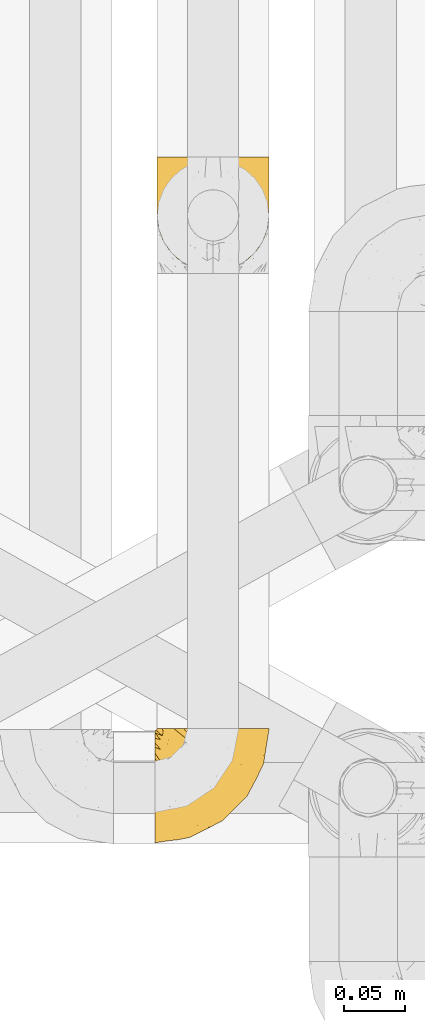
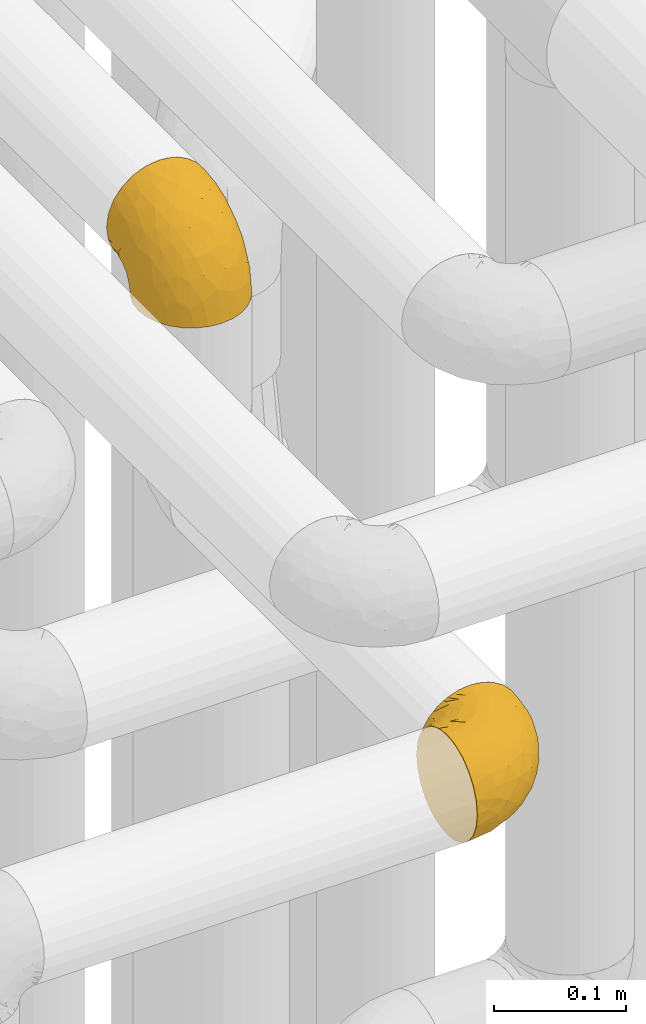
# One storey, part 149 of 827: 2 coverings.
"""IFC2X3 building model written with IfcOpenShell, lengths in millimetres."""

from ifc_helpers import new_model, entity, si_unit, converted_unit, derived_unit, direction, frame, origin, place, context, subcontext, project, spatial, faceted_brep, element, save


model = new_model("IFC2X3")

# Units and contexts
model_context = context("Model", 3, precision=0.01, world=origin(), true_north=direction((6.12303176911189e-17, 1.0)))
body_context = subcontext(model_context, "Body", "Model", "MODEL_VIEW")
ifc_project = project(units=[si_unit("LENGTHUNIT", "METRE", prefix="MILLI"), si_unit("AREAUNIT", "SQUARE_METRE"), si_unit("VOLUMEUNIT", "CUBIC_METRE"), converted_unit("PLANEANGLEUNIT", "DEGREE", entity("IfcRatioMeasure", 0.0174532925199433), si_unit("PLANEANGLEUNIT", "RADIAN"), dimensions=[0, 0, 0, 0, 0, 0, 0]), si_unit("MASSUNIT", "GRAM", prefix="KILO"), derived_unit("MASSDENSITYUNIT", [(si_unit("MASSUNIT", "GRAM", prefix="KILO"), 1), (si_unit("LENGTHUNIT", "METRE"), -3)]), derived_unit("MOMENTOFINERTIAUNIT", [(si_unit("LENGTHUNIT", "METRE"), 4)]), si_unit("TIMEUNIT", "SECOND"), si_unit("FREQUENCYUNIT", "HERTZ"), si_unit("THERMODYNAMICTEMPERATUREUNIT", "DEGREE_CELSIUS"), derived_unit("THERMALTRANSMITTANCEUNIT", [(si_unit("MASSUNIT", "GRAM", prefix="KILO"), 1), (si_unit("THERMODYNAMICTEMPERATUREUNIT", "KELVIN"), -1), (si_unit("TIMEUNIT", "SECOND"), -3)]), derived_unit("VOLUMETRICFLOWRATEUNIT", [(si_unit("LENGTHUNIT", "METRE"), 3), (si_unit("TIMEUNIT", "SECOND"), -1)]), derived_unit("MASSFLOWRATEUNIT", [(si_unit("MASSUNIT", "GRAM", prefix="KILO"), 1), (si_unit("TIMEUNIT", "SECOND"), -1)]), derived_unit("ROTATIONALFREQUENCYUNIT", [(si_unit("TIMEUNIT", "SECOND"), -1)]), si_unit("ELECTRICCURRENTUNIT", "AMPERE"), si_unit("ELECTRICVOLTAGEUNIT", "VOLT"), si_unit("POWERUNIT", "WATT"), si_unit("FORCEUNIT", "NEWTON", prefix="KILO"), si_unit("ILLUMINANCEUNIT", "LUX"), si_unit("LUMINOUSFLUXUNIT", "LUMEN"), si_unit("LUMINOUSINTENSITYUNIT", "CANDELA"), derived_unit("USERDEFINED", [(si_unit("MASSUNIT", "GRAM", prefix="KILO"), -1), (si_unit("LENGTHUNIT", "METRE"), -2), (si_unit("TIMEUNIT", "SECOND"), 3), (si_unit("LUMINOUSFLUXUNIT", "LUMEN"), 1)]), derived_unit("LINEARVELOCITYUNIT", [(si_unit("LENGTHUNIT", "METRE"), 1), (si_unit("TIMEUNIT", "SECOND"), -1)]), si_unit("PRESSUREUNIT", "PASCAL"), derived_unit("USERDEFINED", [(si_unit("LENGTHUNIT", "METRE"), -2), (si_unit("MASSUNIT", "GRAM", prefix="KILO"), 1), (si_unit("TIMEUNIT", "SECOND"), -2)]), derived_unit("LINEARFORCEUNIT", [(si_unit("MASSUNIT", "GRAM", prefix="KILO"), 1), (si_unit("LENGTHUNIT", "METRE"), 1), (si_unit("TIMEUNIT", "SECOND"), -2), (si_unit("LENGTHUNIT", "METRE"), -1)]), derived_unit("PLANARFORCEUNIT", [(si_unit("MASSUNIT", "GRAM", prefix="KILO"), 1), (si_unit("LENGTHUNIT", "METRE"), 1), (si_unit("TIMEUNIT", "SECOND"), -2), (si_unit("LENGTHUNIT", "METRE"), -2)])], contexts=[model_context])

# Site, building, storey
site_placement = place(None, origin())
site = spatial("IfcSite", under=ifc_project, at=site_placement, CompositionType="ELEMENT")
building_placement = place(site_placement, origin())
building = spatial("IfcBuilding", under=site, at=building_placement, CompositionType="ELEMENT")
storey_placement = place(building_placement, frame((0.0, 0.0, 28200.0)))
storey = spatial("IfcBuildingStorey", under=building, at=storey_placement, Name="08", CompositionType="ELEMENT", Elevation=28200.0)

# Coverings
covering_1_placement = place(storey_placement, frame((35552.3, 10780.58, 3350.4)))
element("IfcCovering", 1, at=covering_1_placement, inside=storey, Name=":ADSK_", ObjectType=":ADSK_", PredefinedType="INSULATION", context=body_context, shape_type="Brep", body=[
    faceted_brep([(83.91, 18.98, 1.6), (76.59, 11.67, 1.6), (67.83, 6.17, 1.6), (58.07, 2.75, 1.6), (47.8, 1.6, 1.6), (37.51, 2.75, 1.6), (27.74, 6.17, 1.6), (18.98, 11.68, 1.6), (11.67, 19.0, 1.6), (6.17, 27.76, 1.6), (2.75, 37.52, 1.6), (1.6, 47.8, 1.6), (2.06, 51.94, 1.6), (2.41, 55.01, 1.6), (2.75, 58.08, 1.6), (4.46, 62.96, 1.6), (6.17, 67.85, 1.6), (8.93, 72.23, 1.6), (11.68, 76.61, 1.6), (15.34, 80.26, 1.6), (19.0, 83.92, 1.6), (27.76, 89.42, 1.6), (32.64, 91.13, 1.6), (37.52, 92.84, 1.6), (47.8, 94.0, 1.6), (58.08, 92.84, 1.6), (62.96, 91.13, 1.6), (67.85, 89.42, 1.6), (76.61, 83.91, 1.6), (80.26, 80.25, 1.6), (83.92, 76.59, 1.6), (86.67, 72.21, 1.6), (89.42, 67.83, 1.6), (91.13, 62.95, 1.6), (92.84, 58.07, 1.6), (93.18, 55.0, 1.6), (93.53, 51.94, 1.6), (94.0, 47.8, 1.6), (92.84, 37.51, 1.6), (89.42, 27.74, 1.6), (47.8, 95.8, 3.4), (35.84, 95.8, 4.97), (24.7, 95.8, 9.58), (19.91, 95.8, 13.26), (15.13, 95.8, 16.93), (11.46, 95.8, 21.71), (7.78, 95.8, 26.5), (5.48, 95.8, 32.07), (3.17, 95.8, 37.64), (2.69, 95.8, 41.25), (2.42, 95.8, 43.34), (2.14, 95.8, 45.42), (1.6, 95.8, 49.6), (3.17, 95.8, 61.55), (7.78, 95.8, 72.7), (15.13, 95.8, 82.26), (24.7, 95.8, 89.61), (35.84, 95.8, 94.22), (47.8, 95.8, 95.8), (59.75, 95.8, 94.22), (70.9, 95.8, 89.61), (80.46, 95.8, 82.26), (87.81, 95.8, 72.7), (92.42, 95.8, 61.55), (94.0, 95.8, 49.6), (93.45, 95.8, 45.42), (92.9, 95.8, 41.25), (92.42, 95.8, 37.64), (90.11, 95.8, 32.07), (87.81, 95.8, 26.5), (84.13, 95.8, 21.71), (80.46, 95.8, 16.93), (75.68, 95.8, 13.26), (70.9, 95.8, 9.58), (59.75, 95.8, 4.97), (71.98, 60.58, 81.55), (63.6, 74.11, 90.4), (59.72, 51.59, 83.0), (47.8, 66.69, 91.18), (55.16, 76.19, 93.13), (47.8, 84.43, 94.0), (63.76, 31.2, 66.19), (72.22, 42.88, 70.92), (74.18, 79.41, 85.95), (92.52, 60.7, 49.74), (94.0, 61.85, 35.54), (94.0, 65.75, 38.14), (94.0, 69.64, 40.74), (94.0, 73.53, 43.34), (94.0, 77.43, 45.94), (82.14, 74.59, 77.59), (80.34, 54.72, 71.17), (87.52, 64.18, 65.81), (79.59, 37.94, 59.03), (78.25, 25.89, 45.85), (85.01, 34.73, 45.79), (90.25, 42.89, 41.42), (93.2, 49.83, 34.51), (87.23, 48.58, 56.04), (85.55, 22.41, 15.15), (93.0, 78.69, 56.51), (89.31, 81.64, 68.39), (61.31, 6.22, 23.33), (56.86, 12.11, 42.86), (68.34, 14.81, 39.42), (65.71, 21.61, 53.58), (56.99, 22.41, 59.17), (72.15, 30.12, 59.06), (70.34, 10.01, 22.63), (78.36, 15.36, 20.55), (47.8, 3.39, 12.96), (47.8, 19.59, 56.96), (47.8, 30.01, 67.38), (93.06, 41.19, 18.72), (94.0, 48.54, 5.33), (94.0, 49.28, 9.07), (94.0, 49.82, 11.79), (94.0, 50.37, 14.51), (94.0, 50.91, 17.24), (94.0, 51.45, 19.96), (89.88, 31.61, 21.03), (94.0, 80.15, 46.48), (94.0, 82.88, 47.03), (94.0, 85.6, 47.57), (94.0, 88.32, 48.11), (94.0, 90.19, 48.48), (94.0, 92.06, 48.85), (47.8, 6.21, 30.7), (94.0, 54.05, 23.86), (94.0, 56.65, 27.75), (94.0, 59.25, 31.64), (83.7, 24.66, 31.26), (47.8, 40.43, 77.8), (55.9, 35.17, 72.75), (47.8, 12.9, 43.83), (47.8, 53.56, 84.49), (81.75, 85.34, 14.58), (86.43, 78.44, 16.17), (79.8, 84.37, 10.82), (69.84, 89.05, 4.64), (79.5, 82.76, 7.71), (88.08, 86.31, 25.13), (91.6, 83.73, 32.66), (92.93, 77.31, 34.94), (92.43, 87.78, 36.76), (93.24, 87.91, 40.48), (93.36, 81.29, 39.25), (57.25, 93.97, 3.69), (89.41, 70.76, 13.99), (92.89, 63.67, 21.85), (92.66, 62.62, 17.93), (79.58, 90.64, 15.11), (86.51, 84.08, 21.14), (86.29, 76.28, 12.7), (83.91, 77.45, 7.21), (90.94, 88.72, 32.27), (91.94, 71.28, 25.68), (91.98, 68.09, 22.18), (82.79, 91.07, 18.79), (93.16, 57.47, 10.12), (88.76, 70.34, 9.47), (73.94, 91.35, 10.45), (91.89, 62.99, 11.29), (47.8, 94.52, 2.87), (92.22, 76.47, 31.16), (88.56, 69.96, 6.31), (87.72, 89.86, 25.62), (88.33, 78.94, 21.18), (92.18, 73.51, 28.81), (71.78, 89.62, 7.45), (9.09, 84.09, 21.14), (7.51, 86.3, 25.13), (12.8, 91.06, 18.79), (1.6, 88.32, 48.11), (1.6, 92.06, 48.85), (1.6, 82.88, 47.03), (1.6, 85.6, 47.57), (38.35, 93.97, 3.69), (23.84, 89.63, 7.44), (1.6, 50.37, 14.51), (1.6, 49.82, 11.79), (1.6, 48.54, 5.33), (1.6, 49.28, 9.07), (16.1, 82.77, 7.71), (6.84, 70.36, 9.47), (2.66, 77.31, 34.94), (3.37, 76.47, 31.16), (1.6, 69.64, 40.74), (1.6, 65.75, 38.14), (3.16, 87.78, 36.76), (2.35, 87.91, 40.48), (25.77, 89.06, 4.63), (16.02, 90.65, 15.11), (13.85, 85.35, 14.58), (1.6, 73.53, 43.34), (1.6, 77.43, 45.94), (2.23, 81.29, 39.25), (11.69, 77.46, 7.21), (9.31, 76.29, 12.69), (2.43, 57.47, 10.14), (2.71, 63.71, 21.81), (3.61, 68.11, 22.19), (6.18, 70.77, 14.0), (3.66, 71.31, 25.69), (9.17, 78.46, 16.17), (6.77, 69.52, 6.66), (2.93, 62.64, 17.92), (21.66, 91.35, 10.45), (1.6, 59.25, 31.64), (16.09, 84.6, 10.64), (3.7, 62.98, 11.31), (1.6, 51.45, 19.96), (1.6, 54.05, 23.86), (1.6, 56.65, 27.75), (3.99, 83.73, 32.66), (1.6, 80.15, 46.48), (4.65, 88.72, 32.27), (1.6, 61.85, 35.54), (3.43, 73.56, 28.77), (7.27, 78.96, 21.17), (9.46, 91.36, 23.36), (1.6, 50.91, 17.24), (2.4, 62.87, 47.58), (40.43, 76.19, 93.13), (13.57, 73.57, 77.44), (11.3, 56.07, 66.78), (18.65, 49.77, 71.68), (27.26, 44.73, 74.96), (23.61, 60.58, 81.55), (3.07, 47.64, 36.7), (2.69, 78.32, 56.9), (35.87, 51.59, 83.0), (31.99, 74.11, 90.4), (6.71, 76.04, 67.83), (21.41, 79.41, 85.95), (27.24, 14.82, 39.41), (34.26, 6.22, 23.33), (38.73, 12.12, 42.87), (26.97, 23.51, 53.92), (31.83, 31.2, 66.19), (23.4, 34.96, 64.12), (6.91, 33.86, 33.13), (3.4, 38.94, 23.1), (5.84, 30.23, 16.98), (35.73, 20.67, 55.72), (39.69, 35.17, 72.75), (17.6, 15.85, 23.77), (10.38, 22.59, 18.41), (20.6, 21.56, 43.7), (5.36, 55.94, 54.53), (24.84, 9.19, 17.73), (13.87, 25.79, 38.98), (9.06, 41.16, 50.28), (15.99, 37.95, 59.02)], [[[0, 1, 2, 3, 4, 5, 6, 7, 8, 9, 10, 11, 12, 13, 14, 15, 16, 17, 18, 19, 20, 21, 22, 23, 24, 25, 26, 27, 28, 29, 30, 31, 32, 33, 34, 35, 36, 37, 38, 39]], [[40, 41, 42, 43, 44, 45, 46, 47, 48, 49, 50, 51, 52, 53, 54, 55, 56, 57, 58, 59, 60, 61, 62, 63, 64, 65, 66, 67, 68, 69, 70, 71, 72, 73, 74]], [[75, 76, 77]], [[78, 79, 80]], [[77, 81, 82]], [[76, 75, 83]], [[84, 85, 86, 87, 88, 89]], [[90, 91, 92]], [[76, 60, 59]], [[93, 94, 95]], [[90, 62, 61]], [[83, 61, 60]], [[96, 97, 84]], [[98, 93, 95]], [[0, 39, 99]], [[100, 84, 89]], [[62, 101, 63]], [[2, 102, 3]], [[92, 84, 100]], [[103, 102, 104]], [[103, 105, 106]], [[93, 107, 94]], [[1, 108, 2]], [[92, 101, 90]], [[108, 1, 109]], [[102, 110, 3]], [[93, 82, 107]], [[102, 108, 104]], [[111, 106, 112]], [[109, 0, 99]], [[113, 37, 114, 115, 116, 117, 118, 119]], [[120, 38, 113]], [[100, 89, 121, 122, 123, 124, 125, 126, 64]], [[127, 102, 103]], [[97, 119, 128, 129, 130, 85]], [[99, 120, 131]], [[132, 133, 77]], [[59, 80, 79]], [[1, 0, 109]], [[98, 84, 92]], [[94, 109, 131]], [[120, 39, 38]], [[93, 91, 82]], [[104, 94, 105]], [[97, 113, 119]], [[95, 120, 96]], [[83, 90, 61]], [[91, 93, 98]], [[64, 63, 100]], [[100, 63, 101]], [[77, 76, 79]], [[133, 106, 81]], [[84, 97, 85]], [[113, 96, 120]], [[113, 97, 96]], [[37, 113, 38]], [[110, 102, 127]], [[110, 4, 3]], [[103, 111, 134, 127]], [[90, 75, 91]], [[82, 81, 107]], [[91, 75, 82]], [[77, 82, 75]], [[76, 83, 60]], [[90, 83, 75]], [[105, 107, 81]], [[94, 131, 95]], [[105, 94, 107]], [[109, 94, 104]], [[120, 95, 131]], [[98, 95, 96]], [[84, 98, 96]], [[98, 92, 91]], [[106, 105, 81]], [[103, 104, 105]], [[112, 106, 133]], [[103, 106, 111]], [[112, 133, 132]], [[81, 77, 133]], [[77, 78, 135, 132]], [[120, 99, 39]], [[109, 99, 131]], [[59, 58, 80]], [[59, 79, 76]], [[90, 101, 62]], [[100, 101, 92]], [[2, 108, 102]], [[109, 104, 108]], [[78, 77, 79]], [[136, 137, 138]], [[27, 139, 140]], [[141, 142, 143]], [[144, 145, 121]], [[146, 89, 88]], [[147, 139, 25]], [[148, 149, 150]], [[136, 151, 152]], [[147, 40, 74]], [[24, 147, 25]], [[140, 153, 154]], [[33, 116, 34]], [[73, 72, 151]], [[114, 37, 36, 35, 34, 116, 115]], [[146, 155, 144]], [[156, 85, 130]], [[157, 149, 148]], [[151, 158, 152]], [[117, 33, 159]], [[29, 154, 160]], [[161, 74, 73]], [[162, 128, 119]], [[66, 65, 64, 126, 125, 124, 123, 122, 67]], [[163, 147, 24]], [[27, 140, 28]], [[149, 129, 150]], [[139, 27, 26, 25]], [[68, 144, 69]], [[129, 128, 150]], [[164, 87, 86]], [[130, 129, 149]], [[122, 145, 67]], [[154, 153, 148]], [[162, 119, 159]], [[165, 30, 160]], [[150, 160, 148]], [[128, 162, 150]], [[30, 165, 31]], [[145, 144, 68]], [[89, 146, 144]], [[87, 164, 143]], [[166, 155, 142]], [[88, 87, 143]], [[162, 160, 150]], [[160, 30, 29]], [[154, 29, 28]], [[140, 154, 28]], [[160, 154, 148]], [[140, 137, 153]], [[157, 148, 153]], [[156, 130, 157]], [[153, 137, 157]], [[157, 137, 156]], [[167, 137, 136]], [[168, 85, 156]], [[152, 168, 167]], [[167, 168, 156]], [[164, 152, 141]], [[71, 158, 72]], [[152, 167, 136]], [[88, 142, 146]], [[144, 155, 69]], [[146, 142, 155]], [[70, 166, 71]], [[142, 141, 166]], [[70, 69, 155]], [[141, 158, 71]], [[161, 73, 151]], [[138, 137, 140]], [[161, 136, 169]], [[136, 161, 151]], [[74, 161, 169]], [[152, 158, 141]], [[151, 72, 158]], [[168, 152, 164]], [[137, 167, 156]], [[164, 86, 168]], [[85, 168, 86]], [[116, 33, 117]], [[130, 149, 157]], [[67, 145, 68]], [[121, 89, 144]], [[145, 122, 121]], [[40, 147, 163]], [[169, 147, 74]], [[159, 33, 32]], [[162, 159, 32]], [[159, 119, 118, 117]], [[139, 147, 169]], [[139, 169, 138]], [[162, 32, 31]], [[141, 143, 164]], [[88, 143, 142]], [[71, 166, 141]], [[155, 166, 70]], [[139, 138, 140]], [[169, 136, 138]], [[160, 162, 165]], [[162, 31, 165]], [[170, 171, 172]], [[173, 174, 52, 51, 50, 49, 48, 175, 176]], [[177, 178, 41]], [[179, 15, 180]], [[12, 11, 181, 182, 180, 14, 13]], [[183, 21, 20]], [[19, 18, 184]], [[185, 186, 187]], [[186, 188, 187]], [[43, 172, 44]], [[189, 190, 47]], [[23, 22, 21, 191]], [[170, 192, 193]], [[40, 163, 177]], [[194, 195, 196]], [[24, 23, 177]], [[197, 198, 183]], [[199, 15, 179]], [[47, 46, 189]], [[200, 201, 202]], [[201, 203, 204]], [[205, 206, 184]], [[207, 41, 178]], [[16, 15, 199]], [[14, 180, 15]], [[202, 201, 198]], [[208, 201, 200]], [[163, 24, 177]], [[48, 47, 190]], [[196, 195, 189]], [[197, 184, 202]], [[204, 193, 209]], [[210, 211, 212]], [[206, 212, 213]], [[205, 17, 210]], [[184, 206, 202]], [[210, 212, 206]], [[185, 194, 214]], [[189, 215, 190]], [[216, 45, 214]], [[186, 171, 170]], [[189, 216, 196]], [[197, 20, 19]], [[194, 185, 187]], [[197, 183, 20]], [[184, 197, 19]], [[197, 202, 198]], [[206, 200, 202]], [[204, 183, 198]], [[201, 208, 203]], [[203, 208, 217]], [[204, 198, 201]], [[217, 188, 218]], [[193, 219, 170]], [[171, 186, 185]], [[170, 218, 186]], [[170, 219, 218]], [[42, 207, 192]], [[171, 220, 172]], [[216, 189, 46]], [[214, 194, 196]], [[44, 220, 45]], [[214, 196, 216]], [[216, 46, 45]], [[214, 45, 220]], [[192, 43, 42]], [[204, 203, 219]], [[207, 193, 192]], [[209, 193, 178]], [[41, 207, 42]], [[193, 207, 178]], [[43, 192, 172]], [[170, 172, 192]], [[204, 219, 193]], [[219, 203, 218]], [[217, 218, 203]], [[188, 186, 218]], [[206, 213, 200]], [[208, 200, 213]], [[199, 210, 16]], [[215, 189, 195]], [[215, 175, 190]], [[175, 48, 190]], [[199, 179, 221, 211]], [[210, 199, 211]], [[23, 191, 177]], [[40, 177, 41]], [[178, 177, 191]], [[21, 183, 191]], [[209, 191, 183]], [[205, 18, 17]], [[17, 16, 210]], [[171, 185, 214]], [[172, 220, 44]], [[214, 220, 171]], [[191, 209, 178]], [[204, 209, 183]], [[206, 205, 210]], [[18, 205, 184]], [[222, 195, 194, 187, 188, 217]], [[57, 223, 80]], [[224, 225, 226]], [[226, 227, 228]], [[229, 217, 208, 213, 212, 211]], [[230, 52, 174, 173, 176, 175, 215, 195]], [[231, 232, 228]], [[231, 78, 223]], [[223, 57, 232]], [[224, 233, 225]], [[233, 54, 53]], [[234, 232, 56]], [[56, 55, 234]], [[234, 224, 228]], [[235, 236, 237]], [[224, 55, 54]], [[238, 239, 240]], [[52, 230, 53]], [[241, 242, 243]], [[239, 244, 245]], [[11, 10, 242]], [[236, 6, 5]], [[7, 246, 8]], [[8, 247, 9]], [[238, 248, 235]], [[222, 229, 249]], [[242, 211, 221, 179, 180, 182, 181, 11]], [[233, 53, 230]], [[111, 112, 244]], [[250, 6, 236]], [[247, 251, 241]], [[6, 250, 7]], [[127, 236, 110]], [[249, 229, 252]], [[247, 8, 246]], [[235, 246, 250]], [[236, 5, 110]], [[235, 244, 238]], [[237, 236, 127]], [[243, 9, 247]], [[252, 229, 241]], [[56, 232, 57]], [[222, 230, 195]], [[225, 249, 252]], [[249, 233, 230]], [[54, 233, 224]], [[231, 228, 227]], [[245, 132, 231]], [[249, 225, 233]], [[226, 225, 253]], [[235, 250, 236]], [[246, 7, 250]], [[251, 247, 246]], [[243, 247, 241]], [[248, 246, 235]], [[252, 251, 253]], [[229, 222, 217]], [[230, 222, 249]], [[5, 4, 110]], [[237, 127, 134, 111]], [[238, 244, 239]], [[224, 234, 55]], [[232, 234, 228]], [[242, 241, 229]], [[10, 9, 243]], [[211, 242, 229]], [[10, 243, 242]], [[80, 223, 78]], [[80, 58, 57]], [[231, 223, 232]], [[227, 240, 239]], [[224, 226, 228]], [[240, 226, 253]], [[227, 239, 245]], [[226, 240, 227]], [[251, 248, 253]], [[240, 253, 248]], [[244, 235, 237]], [[237, 111, 244]], [[132, 245, 112]], [[112, 245, 244]], [[135, 78, 231, 132]], [[227, 245, 231]], [[248, 238, 240]], [[246, 248, 251]], [[251, 252, 241]], [[225, 252, 253]]]),
])
covering_2_placement = place(storey_placement, frame((35550.5, 10309.29, 3152.2)))
element("IfcCovering", 2, at=covering_2_placement, inside=storey, Name=":ADSK_", ObjectType=":ADSK_", PredefinedType="INSULATION", context=body_context, shape_type="Brep", body=[
    faceted_brep([(78.41, 95.8, 83.91), (85.72, 95.8, 76.59), (91.22, 95.8, 67.83), (94.64, 95.8, 58.07), (95.8, 95.8, 47.8), (94.64, 95.8, 37.51), (91.22, 95.8, 27.74), (85.71, 95.8, 18.98), (78.39, 95.8, 11.67), (69.63, 95.8, 6.17), (59.87, 95.8, 2.75), (49.6, 95.8, 1.6), (45.45, 95.8, 2.06), (42.38, 95.8, 2.41), (39.31, 95.8, 2.75), (34.43, 95.8, 4.46), (29.54, 95.8, 6.17), (25.16, 95.8, 8.93), (20.78, 95.8, 11.68), (17.13, 95.8, 15.34), (13.47, 95.8, 19.0), (7.97, 95.8, 27.76), (6.26, 95.8, 32.64), (4.55, 95.8, 37.52), (3.4, 95.8, 47.8), (4.55, 95.8, 58.08), (6.26, 95.8, 62.96), (7.97, 95.8, 67.85), (13.48, 95.8, 76.61), (17.14, 95.8, 80.26), (20.8, 95.8, 83.92), (25.18, 95.8, 86.67), (29.56, 95.8, 89.42), (34.44, 95.8, 91.13), (39.32, 95.8, 92.84), (42.39, 95.8, 93.18), (45.45, 95.8, 93.53), (49.6, 95.8, 94.0), (59.88, 95.8, 92.84), (69.65, 95.8, 89.42), (1.6, 94.0, 47.8), (1.6, 92.42, 35.84), (1.6, 87.81, 24.7), (1.6, 84.13, 19.91), (1.6, 80.46, 15.13), (1.6, 75.68, 11.46), (1.6, 70.9, 7.78), (1.6, 65.32, 5.48), (1.6, 59.75, 3.17), (1.6, 56.14, 2.69), (1.6, 54.06, 2.42), (1.6, 51.97, 2.14), (1.6, 47.8, 1.6), (1.6, 35.84, 3.17), (1.6, 24.7, 7.78), (1.6, 15.13, 15.13), (1.6, 7.78, 24.7), (1.6, 3.17, 35.84), (1.6, 1.6, 47.8), (1.6, 3.17, 59.75), (1.6, 7.78, 70.9), (1.6, 15.13, 80.46), (1.6, 24.7, 87.81), (1.6, 35.84, 92.42), (1.6, 47.8, 94.0), (1.6, 51.97, 93.45), (1.6, 56.14, 92.9), (1.6, 59.75, 92.42), (1.6, 65.32, 90.11), (1.6, 70.9, 87.81), (1.6, 75.68, 84.13), (1.6, 80.46, 80.46), (1.6, 84.13, 75.68), (1.6, 87.81, 70.9), (1.6, 92.42, 59.75), (36.81, 15.84, 71.98), (23.28, 6.99, 63.6), (45.8, 14.39, 59.72), (30.7, 6.21, 47.8), (21.2, 4.26, 55.16), (12.96, 3.39, 47.8), (66.19, 31.2, 63.76), (54.51, 26.47, 72.22), (17.98, 11.44, 74.18), (36.69, 47.66, 92.52), (35.54, 61.85, 94.0), (31.64, 59.25, 94.0), (27.75, 56.65, 94.0), (23.86, 54.05, 94.0), (19.96, 51.45, 94.0), (22.8, 19.8, 82.14), (42.67, 26.22, 80.34), (33.21, 31.58, 87.52), (59.45, 38.36, 79.59), (71.5, 51.54, 78.25), (62.66, 51.6, 85.01), (54.5, 55.97, 90.25), (47.57, 62.88, 93.2), (48.81, 41.35, 87.23), (74.98, 82.24, 85.55), (18.7, 40.88, 93.0), (15.75, 29.0, 89.31), (91.17, 74.06, 61.31), (85.28, 54.53, 56.86), (82.58, 57.98, 68.34), (75.78, 43.81, 65.71), (74.98, 38.22, 56.99), (67.27, 38.33, 72.15), (87.38, 74.76, 70.34), (82.04, 76.85, 78.36), (94.0, 84.43, 47.8), (77.8, 40.43, 47.8), (67.38, 30.01, 47.8), (56.2, 78.67, 93.06), (48.85, 92.06, 94.0), (48.11, 88.32, 94.0), (47.57, 85.6, 94.0), (47.03, 82.88, 94.0), (46.48, 80.15, 94.0), (45.94, 77.43, 94.0), (65.78, 76.36, 89.88), (17.24, 50.91, 94.0), (14.51, 50.37, 94.0), (11.79, 49.82, 94.0), (9.07, 49.28, 94.0), (7.2, 48.91, 94.0), (5.33, 48.54, 94.0), (91.18, 66.69, 47.8), (43.34, 73.53, 94.0), (40.74, 69.64, 94.0), (38.14, 65.75, 94.0), (72.73, 66.13, 83.7), (56.96, 19.59, 47.8), (62.23, 24.64, 55.9), (84.49, 53.56, 47.8), (43.83, 12.9, 47.8), (12.05, 82.81, 81.75), (18.95, 81.22, 86.43), (13.02, 86.57, 79.8), (8.34, 92.75, 69.84), (14.63, 89.68, 79.5), (11.09, 72.26, 88.08), (13.66, 64.73, 91.6), (20.08, 62.45, 92.93), (9.61, 60.63, 92.43), (9.48, 56.91, 93.24), (16.1, 58.14, 93.36), (3.42, 93.7, 57.25), (26.63, 83.4, 89.41), (33.72, 75.54, 92.89), (34.77, 79.46, 92.66), (6.75, 82.28, 79.58), (13.31, 76.25, 86.51), (21.11, 84.69, 86.29), (19.94, 90.18, 83.91), (6.04, 86.94, 73.94), (8.67, 65.12, 90.94), (26.11, 71.71, 91.94), (29.3, 75.21, 91.98), (6.32, 78.6, 82.79), (39.92, 87.27, 93.16), (27.05, 87.92, 88.76), (34.4, 86.1, 91.89), (2.87, 94.52, 47.8), (20.92, 66.23, 92.22), (27.43, 91.08, 88.56), (7.54, 71.77, 87.72), (18.45, 76.21, 88.33), (23.88, 68.59, 92.18), (7.77, 89.94, 71.78), (13.3, 76.25, 9.09), (11.09, 72.26, 7.51), (6.33, 78.6, 12.8), (9.07, 49.28, 1.6), (5.33, 48.54, 1.6), (14.51, 50.37, 1.6), (11.79, 49.82, 1.6), (3.42, 93.7, 38.35), (7.76, 89.95, 23.84), (47.03, 82.88, 1.6), (47.57, 85.6, 1.6), (48.85, 92.06, 1.6), (48.11, 88.32, 1.6), (14.62, 89.68, 16.1), (27.03, 87.92, 6.84), (20.08, 62.45, 2.66), (20.92, 66.24, 3.37), (27.75, 56.65, 1.6), (31.64, 59.25, 1.6), (9.61, 60.63, 3.16), (9.48, 56.91, 2.35), (8.33, 92.76, 25.77), (6.74, 82.28, 16.02), (12.04, 82.81, 13.85), (23.86, 54.05, 1.6), (19.96, 51.45, 1.6), (16.1, 58.14, 2.23), (19.93, 90.18, 11.69), (21.1, 84.7, 9.31), (39.92, 87.25, 2.43), (33.68, 75.58, 2.71), (29.28, 75.2, 3.61), (26.62, 83.39, 6.18), (26.08, 71.7, 3.66), (18.93, 81.22, 9.17), (27.87, 90.73, 6.77), (34.75, 79.47, 2.93), (6.04, 86.94, 21.66), (38.14, 65.75, 1.6), (12.79, 86.75, 16.09), (34.41, 86.08, 3.7), (45.94, 77.43, 1.6), (43.34, 73.53, 1.6), (40.74, 69.64, 1.6), (13.66, 64.73, 3.99), (17.24, 50.91, 1.6), (8.67, 65.12, 4.65), (35.54, 61.85, 1.6), (23.83, 68.62, 3.43), (18.43, 76.22, 7.27), (6.03, 74.03, 9.46), (46.48, 80.15, 1.6), (34.52, 49.81, 2.4), (21.2, 4.26, 40.43), (23.82, 19.95, 13.57), (41.32, 30.61, 11.3), (47.62, 25.71, 18.65), (52.66, 22.43, 27.26), (36.81, 15.85, 23.61), (49.75, 60.69, 3.07), (19.07, 40.49, 2.69), (45.8, 14.39, 35.87), (23.28, 6.99, 31.99), (21.35, 29.56, 6.71), (17.98, 11.45, 21.41), (82.57, 57.98, 27.24), (91.17, 74.06, 34.26), (85.27, 54.52, 38.73), (73.89, 43.47, 26.97), (66.19, 31.2, 31.83), (62.43, 33.27, 23.4), (63.53, 64.26, 6.91), (58.45, 74.29, 3.4), (67.16, 80.41, 5.84), (62.22, 24.64, 39.69), (81.54, 73.62, 17.6), (74.8, 78.98, 10.38), (75.83, 53.69, 20.6), (41.45, 42.86, 5.36), (76.72, 41.67, 35.73), (88.2, 79.66, 24.84), (71.6, 58.41, 13.87), (56.23, 47.11, 9.06), (59.44, 38.37, 15.99)], [[[0, 1, 2, 3, 4, 5, 6, 7, 8, 9, 10, 11, 12, 13, 14, 15, 16, 17, 18, 19, 20, 21, 22, 23, 24, 25, 26, 27, 28, 29, 30, 31, 32, 33, 34, 35, 36, 37, 38, 39]], [[40, 41, 42, 43, 44, 45, 46, 47, 48, 49, 50, 51, 52, 53, 54, 55, 56, 57, 58, 59, 60, 61, 62, 63, 64, 65, 66, 67, 68, 69, 70, 71, 72, 73, 74]], [[75, 76, 77]], [[78, 79, 80]], [[77, 81, 82]], [[76, 75, 83]], [[84, 85, 86, 87, 88, 89]], [[90, 91, 92]], [[76, 60, 59]], [[93, 94, 95]], [[90, 62, 61]], [[83, 61, 60]], [[96, 97, 84]], [[98, 93, 95]], [[0, 39, 99]], [[100, 84, 89]], [[62, 101, 63]], [[2, 102, 3]], [[92, 84, 100]], [[103, 102, 104]], [[103, 105, 106]], [[93, 107, 94]], [[1, 108, 2]], [[92, 101, 90]], [[108, 1, 109]], [[102, 110, 3]], [[93, 82, 107]], [[102, 108, 104]], [[111, 106, 112]], [[109, 0, 99]], [[113, 37, 114, 115, 116, 117, 118, 119]], [[120, 38, 113]], [[100, 89, 121, 122, 123, 124, 125, 126, 64]], [[127, 102, 103]], [[97, 119, 128, 129, 130, 85]], [[99, 120, 131]], [[132, 133, 77]], [[59, 80, 79]], [[1, 0, 109]], [[98, 84, 92]], [[94, 109, 131]], [[120, 39, 38]], [[93, 91, 82]], [[104, 94, 105]], [[97, 113, 119]], [[95, 120, 96]], [[83, 90, 61]], [[91, 93, 98]], [[64, 63, 100]], [[100, 63, 101]], [[77, 76, 79]], [[133, 106, 81]], [[84, 97, 85]], [[113, 96, 120]], [[113, 97, 96]], [[37, 113, 38]], [[110, 102, 127]], [[110, 4, 3]], [[103, 111, 134, 127]], [[90, 75, 91]], [[82, 81, 107]], [[91, 75, 82]], [[77, 82, 75]], [[76, 83, 60]], [[90, 83, 75]], [[105, 107, 81]], [[94, 131, 95]], [[105, 94, 107]], [[109, 94, 104]], [[120, 95, 131]], [[98, 95, 96]], [[84, 98, 96]], [[98, 92, 91]], [[106, 105, 81]], [[103, 104, 105]], [[112, 106, 133]], [[103, 106, 111]], [[112, 133, 132]], [[81, 77, 133]], [[77, 78, 135, 132]], [[120, 99, 39]], [[109, 99, 131]], [[59, 58, 80]], [[59, 79, 76]], [[90, 101, 62]], [[100, 101, 92]], [[2, 108, 102]], [[109, 104, 108]], [[78, 77, 79]], [[136, 137, 138]], [[27, 139, 140]], [[141, 142, 143]], [[144, 145, 121]], [[146, 89, 88]], [[147, 139, 25]], [[148, 149, 150]], [[136, 151, 152]], [[147, 40, 74]], [[24, 147, 25]], [[140, 153, 154]], [[33, 116, 34]], [[73, 151, 155]], [[114, 37, 36, 35, 34, 116, 115]], [[146, 156, 144]], [[157, 85, 130]], [[158, 149, 148]], [[151, 159, 152]], [[117, 33, 160]], [[29, 154, 161]], [[155, 74, 73]], [[162, 128, 119]], [[66, 65, 64, 126, 125, 124, 123, 122, 67]], [[163, 147, 24]], [[27, 140, 28]], [[149, 129, 150]], [[139, 27, 26, 25]], [[68, 144, 69]], [[129, 128, 150]], [[164, 87, 86]], [[130, 129, 149]], [[122, 145, 67]], [[154, 153, 148]], [[162, 119, 160]], [[165, 30, 161]], [[150, 161, 148]], [[128, 162, 150]], [[30, 165, 31]], [[145, 144, 68]], [[89, 146, 144]], [[87, 164, 143]], [[166, 156, 142]], [[88, 87, 143]], [[162, 161, 150]], [[161, 30, 29]], [[154, 29, 28]], [[140, 154, 28]], [[161, 154, 148]], [[140, 137, 153]], [[158, 148, 153]], [[157, 130, 158]], [[153, 137, 158]], [[158, 137, 157]], [[167, 137, 136]], [[168, 85, 157]], [[152, 168, 167]], [[167, 168, 157]], [[164, 152, 141]], [[151, 73, 72]], [[159, 72, 71]], [[88, 142, 146]], [[144, 156, 69]], [[146, 142, 156]], [[70, 166, 71]], [[142, 141, 166]], [[70, 69, 156]], [[141, 159, 71]], [[167, 136, 152]], [[138, 137, 140]], [[155, 136, 169]], [[136, 155, 151]], [[74, 155, 169]], [[152, 159, 141]], [[151, 72, 159]], [[168, 152, 164]], [[137, 167, 157]], [[164, 86, 168]], [[85, 168, 86]], [[116, 33, 117]], [[130, 149, 158]], [[67, 145, 68]], [[121, 89, 144]], [[145, 122, 121]], [[40, 147, 163]], [[169, 147, 74]], [[160, 33, 32]], [[162, 160, 32]], [[160, 119, 118, 117]], [[139, 147, 169]], [[139, 169, 138]], [[162, 32, 31]], [[141, 143, 164]], [[88, 143, 142]], [[71, 166, 141]], [[156, 166, 70]], [[139, 138, 140]], [[169, 136, 138]], [[161, 162, 165]], [[162, 31, 165]], [[170, 171, 172]], [[173, 174, 52, 51, 50, 49, 48, 175, 176]], [[177, 178, 41]], [[179, 15, 180]], [[12, 11, 181, 182, 180, 14, 13]], [[183, 21, 20]], [[19, 18, 184]], [[185, 186, 187]], [[186, 188, 187]], [[43, 172, 44]], [[189, 190, 47]], [[23, 22, 21, 191]], [[170, 192, 193]], [[40, 163, 177]], [[194, 195, 196]], [[24, 23, 177]], [[197, 198, 183]], [[199, 15, 179]], [[178, 177, 191]], [[47, 46, 189]], [[200, 201, 202]], [[201, 203, 204]], [[205, 206, 184]], [[207, 41, 178]], [[16, 15, 199]], [[14, 180, 15]], [[202, 201, 198]], [[208, 201, 200]], [[163, 24, 177]], [[48, 47, 190]], [[196, 195, 189]], [[197, 184, 202]], [[204, 193, 209]], [[210, 211, 212]], [[206, 212, 213]], [[205, 17, 210]], [[184, 206, 202]], [[210, 212, 206]], [[185, 194, 214]], [[189, 215, 190]], [[216, 45, 214]], [[186, 171, 170]], [[189, 216, 196]], [[197, 20, 19]], [[194, 185, 187]], [[197, 183, 20]], [[184, 197, 19]], [[197, 202, 198]], [[206, 200, 202]], [[204, 183, 198]], [[201, 208, 203]], [[203, 208, 217]], [[204, 198, 201]], [[217, 188, 218]], [[193, 219, 170]], [[171, 186, 185]], [[170, 218, 186]], [[170, 219, 218]], [[42, 207, 192]], [[171, 220, 172]], [[216, 189, 46]], [[214, 194, 196]], [[44, 220, 45]], [[214, 196, 216]], [[216, 46, 45]], [[214, 45, 220]], [[192, 43, 42]], [[204, 203, 219]], [[207, 193, 192]], [[209, 193, 178]], [[41, 207, 42]], [[193, 207, 178]], [[43, 192, 172]], [[170, 172, 192]], [[204, 219, 193]], [[219, 203, 218]], [[217, 218, 203]], [[188, 186, 218]], [[206, 213, 200]], [[208, 200, 213]], [[199, 210, 16]], [[215, 189, 195]], [[215, 175, 190]], [[175, 48, 190]], [[199, 179, 221, 211]], [[210, 199, 211]], [[23, 191, 177]], [[40, 177, 41]], [[191, 183, 209]], [[21, 183, 191]], [[205, 18, 17]], [[17, 16, 210]], [[171, 185, 214]], [[172, 220, 44]], [[214, 220, 171]], [[191, 209, 178]], [[204, 209, 183]], [[206, 205, 210]], [[18, 205, 184]], [[222, 195, 194, 187, 188, 217]], [[57, 223, 80]], [[224, 225, 226]], [[226, 227, 228]], [[229, 217, 208, 213, 212, 211]], [[230, 52, 174, 173, 176, 175, 215, 195]], [[231, 232, 228]], [[231, 78, 223]], [[223, 57, 232]], [[224, 233, 225]], [[233, 54, 53]], [[234, 232, 56]], [[56, 55, 234]], [[234, 224, 228]], [[235, 236, 237]], [[224, 55, 54]], [[238, 239, 240]], [[52, 230, 53]], [[241, 242, 243]], [[231, 227, 244]], [[11, 10, 242]], [[236, 6, 5]], [[7, 245, 8]], [[8, 246, 9]], [[238, 247, 235]], [[222, 229, 248]], [[242, 211, 221, 179, 180, 182, 181, 11]], [[233, 53, 230]], [[111, 112, 249]], [[250, 6, 236]], [[246, 251, 241]], [[6, 250, 7]], [[127, 236, 110]], [[248, 229, 252]], [[246, 8, 245]], [[235, 245, 250]], [[236, 5, 110]], [[235, 249, 238]], [[237, 236, 127]], [[243, 9, 246]], [[252, 229, 241]], [[56, 232, 57]], [[222, 230, 195]], [[225, 248, 252]], [[248, 233, 230]], [[54, 233, 224]], [[231, 228, 227]], [[244, 132, 231]], [[248, 225, 233]], [[226, 225, 253]], [[235, 250, 236]], [[245, 7, 250]], [[251, 246, 245]], [[243, 246, 241]], [[247, 245, 235]], [[252, 251, 253]], [[229, 222, 217]], [[230, 222, 248]], [[5, 4, 110]], [[237, 127, 134, 111]], [[238, 249, 239]], [[224, 234, 55]], [[232, 234, 228]], [[242, 241, 229]], [[10, 9, 243]], [[211, 242, 229]], [[10, 243, 242]], [[80, 223, 78]], [[80, 58, 57]], [[231, 223, 232]], [[227, 240, 239]], [[224, 226, 228]], [[240, 226, 253]], [[227, 239, 244]], [[226, 240, 227]], [[251, 247, 253]], [[240, 253, 247]], [[249, 235, 237]], [[237, 111, 249]], [[244, 239, 249]], [[112, 244, 249]], [[135, 78, 231, 132]], [[112, 132, 244]], [[247, 238, 240]], [[245, 247, 251]], [[251, 252, 241]], [[225, 252, 253]]]),
])

save(model, "model.ifc")
